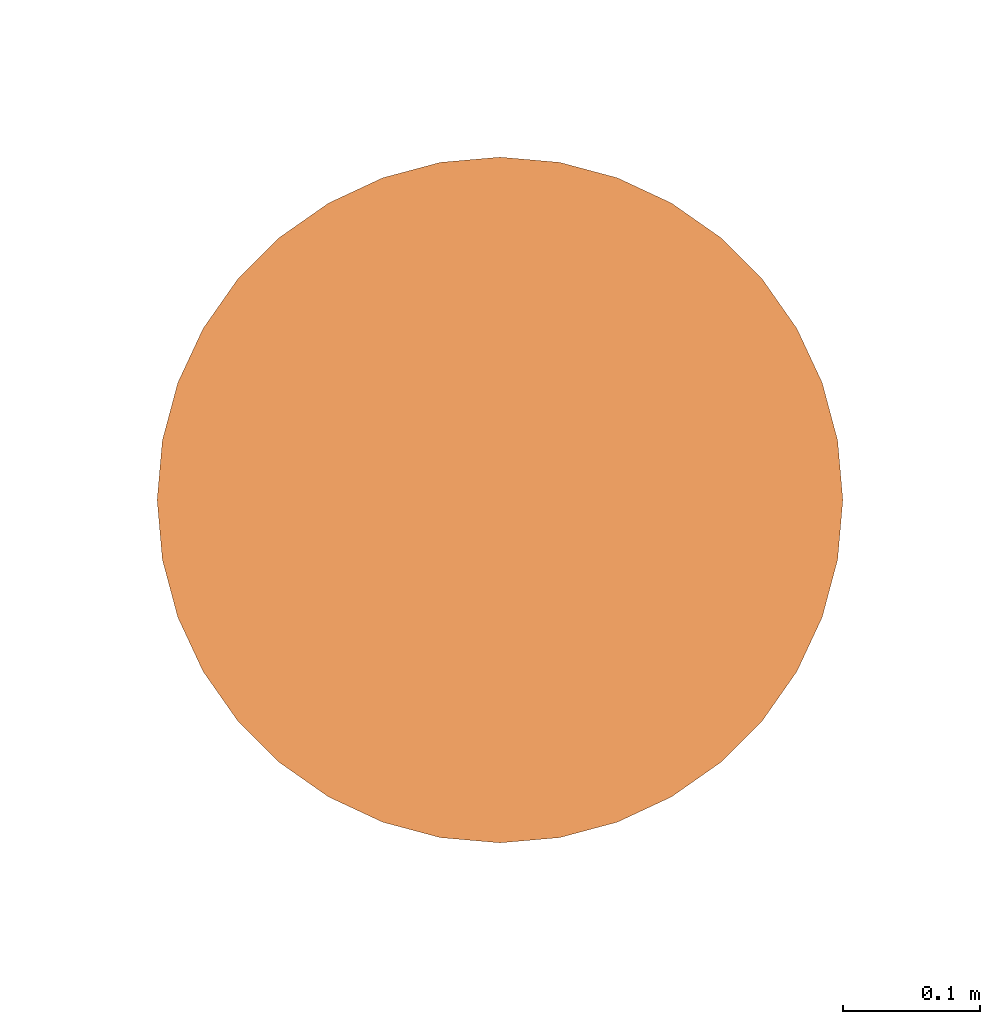
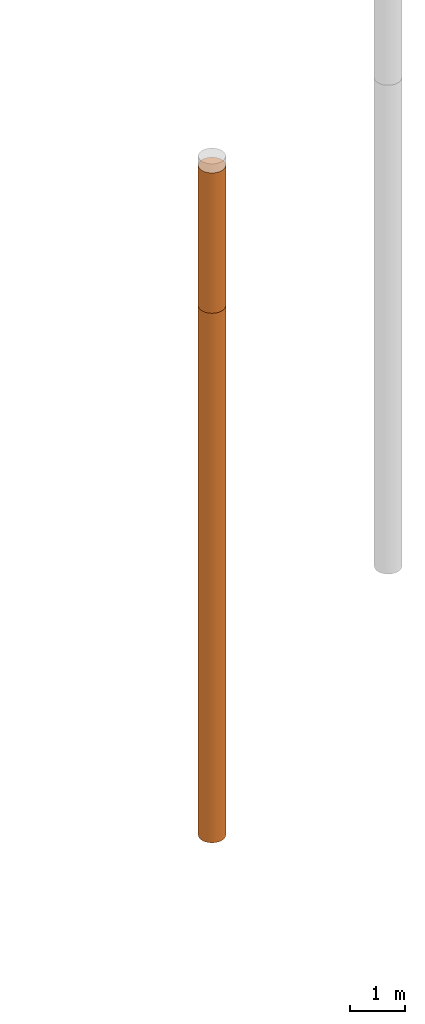
# One storey, part 4 of 8: 2 proxies.
"""IFC4 building model written with IfcOpenShell, lengths in metres."""

from ifc_helpers import new_model, entity, si_unit, converted_unit, frame, origin, place, context, subcontext, project, spatial, faceted_brep, material, element, save


model = new_model("IFC4")

# Units and contexts
model_context = context("Model", 3, precision=1e-05, world=origin())
body_context = subcontext(model_context, "Body", "Model", "MODEL_VIEW")
ifc_project = project(units=[si_unit("LENGTHUNIT", "METRE"), si_unit("AREAUNIT", "SQUARE_METRE"), si_unit("VOLUMEUNIT", "CUBIC_METRE"), converted_unit("PLANEANGLEUNIT", "DEGREE", entity("IfcPlaneAngleMeasure", 0.0174532925199433), si_unit("PLANEANGLEUNIT", "RADIAN"), dimensions=[0, 0, 0, 0, 0, 0, 0])], contexts=[model_context])

# Site, building, storey
site_placement = place(None, origin())
site = spatial("IfcSite", under=ifc_project, at=site_placement, CompositionType="ELEMENT")
building_placement = place(site_placement, origin())
building = spatial("IfcBuilding", under=site, at=building_placement, Name="Demo", CompositionType="ELEMENT")
storey_placement = place(building_placement, origin())
storey = spatial("IfcBuildingStorey", under=building, at=storey_placement, Name="Boden", CompositionType="ELEMENT", Elevation=0.0)

# Proxies
ifc_material_1 = material()
proxy_1_placement = place(storey_placement, frame((9.9, 9.49, -3.3)))
element("IfcBuildingElementProxy", 1, at=proxy_1_placement, inside=storey, material=ifc_material_1, Name="KB-05_Sand", PredefinedType="USERDEFINED", context=body_context, shape_type="Brep", body=[
    faceted_brep([(0.4962019382530525, 0.2934120444167329, 3.1), (0.5, 0.25, 3.1), (0.4962019382530525, 0.2065879555832671, 3.1), (0.4849231551964767, 0.1644949641685835, 3.1), (0.4665063509461107, 0.125, 3.1), (0.4415111107797439, 0.08930309757836585, 3.1), (0.4106969024216342, 0.05848888922025617, 3.1), (0.375, 0.0334936490538912, 3.1), (0.3355050358314166, 0.01507684480352327, 3.1), (0.2934120444167329, 0.003798061746947497, 3.1), (0.25, 0.0, 3.1), (0.2065879555832671, 0.003798061746947497, 3.1), (0.1644949641685835, 0.01507684480352327, 3.1), (0.125, 0.03349364905388939, 3.1), (0.08930309757836585, 0.05848888922025617, 3.1), (0.05848888922025617, 0.08930309757836585, 3.1), (0.0334936490538912, 0.125, 3.1), (0.01507684480352327, 0.1644949641685835, 3.1), (0.003798061746947497, 0.2065879555832671, 3.1), (0.0, 0.25, 3.1), (0.003798061746947497, 0.2934120444167329, 3.1), (0.01507684480352327, 0.3355050358314166, 3.1), (0.03349364905388939, 0.375, 3.1), (0.05848888922025435, 0.4106969024216342, 3.1), (0.08930309757836404, 0.4415111107797439, 3.1), (0.125, 0.4665063509461088, 3.1), (0.1644949641685816, 0.4849231551964767, 3.1), (0.2065879555832671, 0.4962019382530525, 3.1), (0.25, 0.5, 3.1), (0.2934120444167311, 0.4962019382530525, 3.1), (0.3355050358314166, 0.4849231551964767, 3.1), (0.375, 0.4665063509461107, 3.1), (0.4106969024216342, 0.4415111107797456, 3.1), (0.4415111107797439, 0.410696902421636, 3.1), (0.4665063509461088, 0.375, 3.1), (0.4849231551964767, 0.3355050358314184, 3.1), (0.5, 0.25, 0.0), (0.4962019382530525, 0.2934120444167329, 0.0), (0.4849231551964767, 0.3355050358314184, 0.0), (0.4665063509461088, 0.375, 0.0), (0.4415111107797439, 0.410696902421636, 0.0), (0.4106969024216342, 0.4415111107797456, 0.0), (0.375, 0.4665063509461107, 0.0), (0.3355050358314166, 0.4849231551964767, 0.0), (0.2934120444167311, 0.4962019382530525, 0.0), (0.25, 0.5, 0.0), (0.2065879555832671, 0.4962019382530507, 0.0), (0.1644949641685816, 0.4849231551964767, 0.0), (0.125, 0.4665063509461088, 0.0), (0.08930309757836404, 0.4415111107797439, 0.0), (0.05848888922025435, 0.4106969024216342, 0.0), (0.03349364905388939, 0.375, 0.0), (0.01507684480352327, 0.3355050358314166, 0.0), (0.003798061746947497, 0.2934120444167311, 0.0), (0.0, 0.25, 0.0), (0.003798061746947497, 0.2065879555832671, 0.0), (0.01507684480352327, 0.1644949641685816, 0.0), (0.0334936490538912, 0.125, 0.0), (0.05848888922025617, 0.08930309757836404, 0.0), (0.08930309757836585, 0.05848888922025435, 0.0), (0.125, 0.03349364905388939, 0.0), (0.1644949641685835, 0.01507684480352327, 0.0), (0.2065879555832671, 0.003798061746947497, 0.0), (0.25, 0.0, 0.0), (0.2934120444167329, 0.003798061746947497, 0.0), (0.3355050358314166, 0.01507684480352327, 0.0), (0.375, 0.03349364905388939, 0.0), (0.4106969024216342, 0.05848888922025435, 0.0), (0.4415111107797439, 0.08930309757836404, 0.0), (0.4665063509461107, 0.125, 0.0), (0.4849231551964767, 0.1644949641685816, 0.0), (0.4962019382530525, 0.2065879555832671, 0.0), (0.5, 0.25, 3.1), (0.4962019382530525, 0.2934120444167329, 3.1), (0.4962019382530525, 0.2934120444167329, 0.0), (0.5, 0.25, 0.0), (0.4962019382530525, 0.2065879555832671, 3.1), (0.5, 0.25, 3.1), (0.5, 0.25, 0.0), (0.4962019382530525, 0.2065879555832671, 0.0), (0.4849231551964767, 0.1644949641685835, 3.1), (0.4962019382530525, 0.2065879555832671, 3.1), (0.4962019382530525, 0.2065879555832671, 0.0), (0.4849231551964767, 0.1644949641685816, 0.0), (0.4665063509461107, 0.125, 3.1), (0.4849231551964767, 0.1644949641685835, 3.1), (0.4849231551964767, 0.1644949641685816, 0.0), (0.4665063509461107, 0.125, 0.0), (0.4415111107797439, 0.08930309757836585, 3.1), (0.4665063509461107, 0.125, 3.1), (0.4665063509461107, 0.125, 0.0), (0.4415111107797439, 0.08930309757836404, 0.0), (0.4106969024216342, 0.05848888922025617, 3.1), (0.4415111107797439, 0.08930309757836585, 3.1), (0.4415111107797439, 0.08930309757836404, 0.0), (0.4106969024216342, 0.05848888922025435, 0.0), (0.375, 0.0334936490538912, 3.1), (0.4106969024216342, 0.05848888922025617, 3.1), (0.4106969024216342, 0.05848888922025435, 0.0), (0.375, 0.03349364905388939, 0.0), (0.3355050358314166, 0.01507684480352327, 3.1), (0.375, 0.0334936490538912, 3.1), (0.375, 0.03349364905388939, 0.0), (0.3355050358314166, 0.01507684480352327, 0.0), (0.2934120444167329, 0.003798061746947497, 3.1), (0.3355050358314166, 0.01507684480352327, 3.1), (0.3355050358314166, 0.01507684480352327, 0.0), (0.2934120444167329, 0.003798061746947497, 0.0), (0.25, 0.0, 3.1), (0.2934120444167329, 0.003798061746947497, 3.1), (0.2934120444167329, 0.003798061746947497, 0.0), (0.25, 0.0, 0.0), (0.2065879555832671, 0.003798061746947497, 3.1), (0.25, 0.0, 3.1), (0.25, 0.0, 0.0), (0.2065879555832671, 0.003798061746947497, 0.0), (0.1644949641685835, 0.01507684480352327, 3.1), (0.2065879555832671, 0.003798061746947497, 3.1), (0.2065879555832671, 0.003798061746947497, 0.0), (0.1644949641685835, 0.01507684480352327, 0.0), (0.125, 0.03349364905388939, 3.1), (0.1644949641685835, 0.01507684480352327, 3.1), (0.1644949641685835, 0.01507684480352327, 0.0), (0.125, 0.03349364905388939, 0.0), (0.08930309757836585, 0.05848888922025617, 3.1), (0.125, 0.03349364905388939, 3.1), (0.125, 0.03349364905388939, 0.0), (0.08930309757836585, 0.05848888922025435, 0.0), (0.05848888922025617, 0.08930309757836585, 3.1), (0.08930309757836585, 0.05848888922025617, 3.1), (0.08930309757836585, 0.05848888922025435, 0.0), (0.05848888922025617, 0.08930309757836404, 0.0), (0.0334936490538912, 0.125, 3.1), (0.05848888922025617, 0.08930309757836585, 3.1), (0.05848888922025617, 0.08930309757836404, 0.0), (0.0334936490538912, 0.125, 0.0), (0.01507684480352327, 0.1644949641685835, 3.1), (0.0334936490538912, 0.125, 3.1), (0.0334936490538912, 0.125, 0.0), (0.01507684480352327, 0.1644949641685816, 0.0), (0.003798061746947497, 0.2065879555832671, 3.1), (0.01507684480352327, 0.1644949641685835, 3.1), (0.01507684480352327, 0.1644949641685816, 0.0), (0.003798061746947497, 0.2065879555832671, 0.0), (0.0, 0.25, 3.1), (0.003798061746947497, 0.2065879555832671, 3.1), (0.003798061746947497, 0.2065879555832671, 0.0), (0.0, 0.25, 0.0), (0.003798061746947497, 0.2934120444167329, 3.1), (0.0, 0.25, 3.1), (0.0, 0.25, 0.0), (0.003798061746947497, 0.2934120444167311, 0.0), (0.01507684480352327, 0.3355050358314166, 3.1), (0.003798061746947497, 0.2934120444167329, 3.1), (0.003798061746947497, 0.2934120444167311, 0.0), (0.01507684480352327, 0.3355050358314166, 0.0), (0.03349364905388939, 0.375, 3.1), (0.01507684480352327, 0.3355050358314166, 3.1), (0.01507684480352327, 0.3355050358314166, 0.0), (0.03349364905388939, 0.375, 0.0), (0.05848888922025435, 0.4106969024216342, 3.1), (0.03349364905388939, 0.375, 3.1), (0.03349364905388939, 0.375, 0.0), (0.05848888922025435, 0.4106969024216342, 0.0), (0.08930309757836404, 0.4415111107797439, 3.1), (0.05848888922025435, 0.4106969024216342, 3.1), (0.05848888922025435, 0.4106969024216342, 0.0), (0.08930309757836404, 0.4415111107797439, 0.0), (0.125, 0.4665063509461088, 3.1), (0.08930309757836404, 0.4415111107797439, 3.1), (0.08930309757836404, 0.4415111107797439, 0.0), (0.125, 0.4665063509461088, 0.0), (0.1644949641685816, 0.4849231551964767, 3.1), (0.125, 0.4665063509461088, 3.1), (0.125, 0.4665063509461088, 0.0), (0.1644949641685816, 0.4849231551964767, 0.0), (0.2065879555832671, 0.4962019382530525, 3.1), (0.1644949641685816, 0.4849231551964767, 3.1), (0.1644949641685816, 0.4849231551964767, 0.0), (0.2065879555832671, 0.4962019382530507, 0.0), (0.25, 0.5, 3.1), (0.2065879555832671, 0.4962019382530525, 3.1), (0.2065879555832671, 0.4962019382530507, 0.0), (0.25, 0.5, 0.0), (0.2934120444167311, 0.4962019382530525, 3.1), (0.25, 0.5, 3.1), (0.25, 0.5, 0.0), (0.2934120444167311, 0.4962019382530525, 0.0), (0.3355050358314166, 0.4849231551964767, 3.1), (0.2934120444167311, 0.4962019382530525, 3.1), (0.2934120444167311, 0.4962019382530525, 0.0), (0.3355050358314166, 0.4849231551964767, 0.0), (0.375, 0.4665063509461107, 3.1), (0.3355050358314166, 0.4849231551964767, 3.1), (0.3355050358314166, 0.4849231551964767, 0.0), (0.375, 0.4665063509461107, 0.0), (0.4106969024216342, 0.4415111107797456, 3.1), (0.375, 0.4665063509461107, 3.1), (0.375, 0.4665063509461107, 0.0), (0.4106969024216342, 0.4415111107797456, 0.0), (0.4415111107797439, 0.410696902421636, 3.1), (0.4106969024216342, 0.4415111107797456, 3.1), (0.4106969024216342, 0.4415111107797456, 0.0), (0.4415111107797439, 0.410696902421636, 0.0), (0.4665063509461088, 0.375, 3.1), (0.4415111107797439, 0.410696902421636, 3.1), (0.4415111107797439, 0.410696902421636, 0.0), (0.4665063509461088, 0.375, 0.0), (0.4849231551964767, 0.3355050358314184, 3.1), (0.4665063509461088, 0.375, 3.1), (0.4665063509461088, 0.375, 0.0), (0.4849231551964767, 0.3355050358314184, 0.0), (0.4962019382530525, 0.2934120444167329, 3.1), (0.4849231551964767, 0.3355050358314184, 3.1), (0.4849231551964767, 0.3355050358314184, 0.0), (0.4962019382530525, 0.2934120444167329, 0.0)], [[[0, 1, 2, 3, 4, 5, 6, 7, 8, 9, 10, 11, 12, 13, 14, 15, 16, 17, 18, 19, 20, 21, 22, 23, 24, 25, 26, 27, 28, 29, 30, 31, 32, 33, 34, 35]], [[36, 37, 38, 39, 40, 41, 42, 43, 44, 45, 46, 47, 48, 49, 50, 51, 52, 53, 54, 55, 56, 57, 58, 59, 60, 61, 62, 63, 64, 65, 66, 67, 68, 69, 70, 71]], [[72, 73, 74, 75]], [[76, 77, 78, 79]], [[80, 81, 82, 83]], [[84, 85, 86, 87]], [[88, 89, 90, 91]], [[92, 93, 94, 95]], [[96, 97, 98, 99]], [[100, 101, 102, 103]], [[104, 105, 106, 107]], [[108, 109, 110, 111]], [[112, 113, 114, 115]], [[116, 117, 118, 119]], [[120, 121, 122, 123]], [[124, 125, 126, 127]], [[128, 129, 130, 131]], [[132, 133, 134, 135]], [[136, 137, 138, 139]], [[140, 141, 142, 143]], [[144, 145, 146, 147]], [[148, 149, 150, 151]], [[152, 153, 154, 155]], [[156, 157, 158, 159]], [[160, 161, 162, 163]], [[164, 165, 166, 167]], [[168, 169, 170, 171]], [[172, 173, 174, 175]], [[176, 177, 178, 179]], [[180, 181, 182, 183]], [[184, 185, 186, 187]], [[188, 189, 190, 191]], [[192, 193, 194, 195]], [[196, 197, 198, 199]], [[200, 201, 202, 203]], [[204, 205, 206, 207]], [[208, 209, 210, 211]], [[212, 213, 214, 215]]], orient=[[False], [False], [False], [False], [False], [False], [False], [False], [False], [False], [False], [False], [False], [False], [False], [False], [False], [False], [False], [False], [False], [False], [False], [False], [False], [False], [False], [False], [False], [False], [False], [False], [False], [False], [False], [False], [False], [False]]),
])
ifc_material_2 = material()
proxy_2_placement = place(storey_placement, frame((9.9, 9.49, -15.0)))
element("IfcBuildingElementProxy", 2, at=proxy_2_placement, inside=storey, material=ifc_material_2, Name="KB-05_Kies", PredefinedType="USERDEFINED", context=body_context, shape_type="Brep", body=[
    faceted_brep([(0.4962019382530525, 0.2934120444167329, 11.7), (0.5, 0.25, 11.7), (0.4962019382530525, 0.2065879555832671, 11.7), (0.4849231551964767, 0.1644949641685835, 11.7), (0.4665063509461107, 0.125, 11.7), (0.4415111107797439, 0.08930309757836585, 11.7), (0.4106969024216342, 0.05848888922025617, 11.7), (0.375, 0.0334936490538912, 11.7), (0.3355050358314166, 0.01507684480352327, 11.7), (0.2934120444167329, 0.003798061746947497, 11.7), (0.25, 0.0, 11.7), (0.2065879555832671, 0.003798061746947497, 11.7), (0.1644949641685835, 0.01507684480352327, 11.7), (0.125, 0.03349364905388939, 11.7), (0.08930309757836585, 0.05848888922025617, 11.7), (0.05848888922025617, 0.08930309757836585, 11.7), (0.0334936490538912, 0.125, 11.7), (0.01507684480352327, 0.1644949641685835, 11.7), (0.003798061746947497, 0.2065879555832671, 11.7), (0.0, 0.25, 11.7), (0.003798061746947497, 0.2934120444167329, 11.7), (0.01507684480352327, 0.3355050358314166, 11.7), (0.03349364905388939, 0.375, 11.7), (0.05848888922025435, 0.4106969024216342, 11.7), (0.08930309757836404, 0.4415111107797439, 11.7), (0.125, 0.4665063509461088, 11.7), (0.1644949641685816, 0.4849231551964767, 11.7), (0.2065879555832671, 0.4962019382530525, 11.7), (0.25, 0.5, 11.7), (0.2934120444167311, 0.4962019382530525, 11.7), (0.3355050358314166, 0.4849231551964767, 11.7), (0.375, 0.4665063509461107, 11.7), (0.4106969024216342, 0.4415111107797456, 11.7), (0.4415111107797439, 0.410696902421636, 11.7), (0.4665063509461088, 0.375, 11.7), (0.4849231551964767, 0.3355050358314184, 11.7), (0.5, 0.2499999999999982, 0.0), (0.4962019382530525, 0.2934120444167329, 0.0), (0.4849231551964767, 0.3355050358314166, 0.0), (0.4665063509461088, 0.375, 0.0), (0.4415111107797439, 0.4106969024216342, 0.0), (0.4106969024216342, 0.4415111107797439, 0.0), (0.375, 0.4665063509461088, 0.0), (0.3355050358314166, 0.4849231551964767, 0.0), (0.2934120444167311, 0.4962019382530507, 0.0), (0.25, 0.4999999999999982, 0.0), (0.2065879555832671, 0.4962019382530507, 0.0), (0.1644949641685816, 0.4849231551964749, 0.0), (0.125, 0.4665063509461088, 0.0), (0.08930309757836404, 0.441511110779742, 0.0), (0.05848888922025435, 0.4106969024216323, 0.0), (0.03349364905388939, 0.3749999999999982, 0.0), (0.01507684480352327, 0.3355050358314147, 0.0), (0.003798061746947497, 0.2934120444167311, 0.0), (0.0, 0.2499999999999982, 0.0), (0.003798061746947497, 0.2065879555832653, 0.0), (0.01507684480352327, 0.1644949641685816, 0.0), (0.0334936490538912, 0.1249999999999982, 0.0), (0.05848888922025617, 0.08930309757836404, 0.0), (0.08930309757836585, 0.05848888922025435, 0.0), (0.125, 0.03349364905388939, 0.0), (0.1644949641685835, 0.01507684480352145, 0.0), (0.2065879555832671, 0.003798061746947497, 0.0), (0.25, -1.818989403545857e-15, 0.0), (0.2934120444167329, 0.003798061746947497, 0.0), (0.3355050358314166, 0.01507684480352145, 0.0), (0.375, 0.03349364905388939, 0.0), (0.4106969024216342, 0.05848888922025435, 0.0), (0.4415111107797439, 0.08930309757836404, 0.0), (0.4665063509461107, 0.1249999999999982, 0.0), (0.4849231551964767, 0.1644949641685816, 0.0), (0.4962019382530525, 0.2065879555832653, 0.0), (0.5, 0.25, 11.7), (0.4962019382530525, 0.2934120444167329, 11.7), (0.4962019382530525, 0.2934120444167329, 0.0), (0.5, 0.2499999999999982, 0.0), (0.4962019382530525, 0.2065879555832671, 11.7), (0.5, 0.25, 11.7), (0.5, 0.2499999999999982, 0.0), (0.4962019382530525, 0.2065879555832653, 0.0), (0.4849231551964767, 0.1644949641685835, 11.7), (0.4962019382530525, 0.2065879555832671, 11.7), (0.4962019382530525, 0.2065879555832653, 0.0), (0.4849231551964767, 0.1644949641685816, 0.0), (0.4665063509461107, 0.125, 11.7), (0.4849231551964767, 0.1644949641685835, 11.7), (0.4849231551964767, 0.1644949641685816, 0.0), (0.4665063509461107, 0.1249999999999982, 0.0), (0.4415111107797439, 0.08930309757836585, 11.7), (0.4665063509461107, 0.125, 11.7), (0.4665063509461107, 0.1249999999999982, 0.0), (0.4415111107797439, 0.08930309757836404, 0.0), (0.4106969024216342, 0.05848888922025617, 11.7), (0.4415111107797439, 0.08930309757836585, 11.7), (0.4415111107797439, 0.08930309757836404, 0.0), (0.4106969024216342, 0.05848888922025435, 0.0), (0.375, 0.0334936490538912, 11.7), (0.4106969024216342, 0.05848888922025617, 11.7), (0.4106969024216342, 0.05848888922025435, 0.0), (0.375, 0.03349364905388939, 0.0), (0.3355050358314166, 0.01507684480352327, 11.7), (0.375, 0.0334936490538912, 11.7), (0.375, 0.03349364905388939, 0.0), (0.3355050358314166, 0.01507684480352145, 0.0), (0.2934120444167329, 0.003798061746947497, 11.7), (0.3355050358314166, 0.01507684480352327, 11.7), (0.3355050358314166, 0.01507684480352145, 0.0), (0.2934120444167329, 0.003798061746947497, 0.0), (0.25, 0.0, 11.7), (0.2934120444167329, 0.003798061746947497, 11.7), (0.2934120444167329, 0.003798061746947497, 0.0), (0.25, -1.818989403545857e-15, 0.0), (0.2065879555832671, 0.003798061746947497, 11.7), (0.25, 0.0, 11.7), (0.25, -1.818989403545857e-15, 0.0), (0.2065879555832671, 0.003798061746947497, 0.0), (0.1644949641685835, 0.01507684480352327, 11.7), (0.2065879555832671, 0.003798061746947497, 11.7), (0.2065879555832671, 0.003798061746947497, 0.0), (0.1644949641685835, 0.01507684480352145, 0.0), (0.125, 0.03349364905388939, 11.7), (0.1644949641685835, 0.01507684480352327, 11.7), (0.1644949641685835, 0.01507684480352145, 0.0), (0.125, 0.03349364905388939, 0.0), (0.08930309757836585, 0.05848888922025617, 11.7), (0.125, 0.03349364905388939, 11.7), (0.125, 0.03349364905388939, 0.0), (0.08930309757836585, 0.05848888922025435, 0.0), (0.05848888922025617, 0.08930309757836585, 11.7), (0.08930309757836585, 0.05848888922025617, 11.7), (0.08930309757836585, 0.05848888922025435, 0.0), (0.05848888922025617, 0.08930309757836404, 0.0), (0.0334936490538912, 0.125, 11.7), (0.05848888922025617, 0.08930309757836585, 11.7), (0.05848888922025617, 0.08930309757836404, 0.0), (0.0334936490538912, 0.1249999999999982, 0.0), (0.01507684480352327, 0.1644949641685835, 11.7), (0.0334936490538912, 0.125, 11.7), (0.0334936490538912, 0.1249999999999982, 0.0), (0.01507684480352327, 0.1644949641685816, 0.0), (0.003798061746947497, 0.2065879555832671, 11.7), (0.01507684480352327, 0.1644949641685835, 11.7), (0.01507684480352327, 0.1644949641685816, 0.0), (0.003798061746947497, 0.2065879555832653, 0.0), (0.0, 0.25, 11.7), (0.003798061746947497, 0.2065879555832671, 11.7), (0.003798061746947497, 0.2065879555832653, 0.0), (0.0, 0.2499999999999982, 0.0), (0.003798061746947497, 0.2934120444167329, 11.7), (0.0, 0.25, 11.7), (0.0, 0.2499999999999982, 0.0), (0.003798061746947497, 0.2934120444167311, 0.0), (0.01507684480352327, 0.3355050358314166, 11.7), (0.003798061746947497, 0.2934120444167329, 11.7), (0.003798061746947497, 0.2934120444167311, 0.0), (0.01507684480352327, 0.3355050358314147, 0.0), (0.03349364905388939, 0.375, 11.7), (0.01507684480352327, 0.3355050358314166, 11.7), (0.01507684480352327, 0.3355050358314147, 0.0), (0.03349364905388939, 0.3749999999999982, 0.0), (0.05848888922025435, 0.4106969024216342, 11.7), (0.03349364905388939, 0.375, 11.7), (0.03349364905388939, 0.3749999999999982, 0.0), (0.05848888922025435, 0.4106969024216323, 0.0), (0.08930309757836404, 0.4415111107797439, 11.7), (0.05848888922025435, 0.4106969024216342, 11.7), (0.05848888922025435, 0.4106969024216323, 0.0), (0.08930309757836404, 0.441511110779742, 0.0), (0.125, 0.4665063509461088, 11.7), (0.08930309757836404, 0.4415111107797439, 11.7), (0.08930309757836404, 0.441511110779742, 0.0), (0.125, 0.4665063509461088, 0.0), (0.1644949641685816, 0.4849231551964767, 11.7), (0.125, 0.4665063509461088, 11.7), (0.125, 0.4665063509461088, 0.0), (0.1644949641685816, 0.4849231551964749, 0.0), (0.2065879555832671, 0.4962019382530525, 11.7), (0.1644949641685816, 0.4849231551964767, 11.7), (0.1644949641685816, 0.4849231551964749, 0.0), (0.2065879555832671, 0.4962019382530507, 0.0), (0.25, 0.5, 11.7), (0.2065879555832671, 0.4962019382530525, 11.7), (0.2065879555832671, 0.4962019382530507, 0.0), (0.25, 0.4999999999999982, 0.0), (0.2934120444167311, 0.4962019382530525, 11.7), (0.25, 0.5, 11.7), (0.25, 0.4999999999999982, 0.0), (0.2934120444167311, 0.4962019382530507, 0.0), (0.3355050358314166, 0.4849231551964767, 11.7), (0.2934120444167311, 0.4962019382530525, 11.7), (0.2934120444167311, 0.4962019382530507, 0.0), (0.3355050358314166, 0.4849231551964767, 0.0), (0.375, 0.4665063509461107, 11.7), (0.3355050358314166, 0.4849231551964767, 11.7), (0.3355050358314166, 0.4849231551964767, 0.0), (0.375, 0.4665063509461088, 0.0), (0.4106969024216342, 0.4415111107797456, 11.7), (0.375, 0.4665063509461107, 11.7), (0.375, 0.4665063509461088, 0.0), (0.4106969024216342, 0.4415111107797439, 0.0), (0.4415111107797439, 0.410696902421636, 11.7), (0.4106969024216342, 0.4415111107797456, 11.7), (0.4106969024216342, 0.4415111107797439, 0.0), (0.4415111107797439, 0.4106969024216342, 0.0), (0.4665063509461088, 0.375, 11.7), (0.4415111107797439, 0.410696902421636, 11.7), (0.4415111107797439, 0.4106969024216342, 0.0), (0.4665063509461088, 0.375, 0.0), (0.4849231551964767, 0.3355050358314184, 11.7), (0.4665063509461088, 0.375, 11.7), (0.4665063509461088, 0.375, 0.0), (0.4849231551964767, 0.3355050358314166, 0.0), (0.4962019382530525, 0.2934120444167329, 11.7), (0.4849231551964767, 0.3355050358314184, 11.7), (0.4849231551964767, 0.3355050358314166, 0.0), (0.4962019382530525, 0.2934120444167329, 0.0)], [[[0, 1, 2, 3, 4, 5, 6, 7, 8, 9, 10, 11, 12, 13, 14, 15, 16, 17, 18, 19, 20, 21, 22, 23, 24, 25, 26, 27, 28, 29, 30, 31, 32, 33, 34, 35]], [[36, 37, 38, 39, 40, 41, 42, 43, 44, 45, 46, 47, 48, 49, 50, 51, 52, 53, 54, 55, 56, 57, 58, 59, 60, 61, 62, 63, 64, 65, 66, 67, 68, 69, 70, 71]], [[72, 73, 74, 75]], [[76, 77, 78, 79]], [[80, 81, 82, 83]], [[84, 85, 86, 87]], [[88, 89, 90, 91]], [[92, 93, 94, 95]], [[96, 97, 98, 99]], [[100, 101, 102, 103]], [[104, 105, 106, 107]], [[108, 109, 110, 111]], [[112, 113, 114, 115]], [[116, 117, 118, 119]], [[120, 121, 122, 123]], [[124, 125, 126, 127]], [[128, 129, 130, 131]], [[132, 133, 134, 135]], [[136, 137, 138, 139]], [[140, 141, 142, 143]], [[144, 145, 146, 147]], [[148, 149, 150, 151]], [[152, 153, 154, 155]], [[156, 157, 158, 159]], [[160, 161, 162, 163]], [[164, 165, 166, 167]], [[168, 169, 170, 171]], [[172, 173, 174, 175]], [[176, 177, 178, 179]], [[180, 181, 182, 183]], [[184, 185, 186, 187]], [[188, 189, 190, 191]], [[192, 193, 194, 195]], [[196, 197, 198, 199]], [[200, 201, 202, 203]], [[204, 205, 206, 207]], [[208, 209, 210, 211]], [[212, 213, 214, 215]]], orient=[[False], [False], [False], [False], [False], [False], [False], [False], [False], [False], [False], [False], [False], [False], [False], [False], [False], [False], [False], [False], [False], [False], [False], [False], [False], [False], [False], [False], [False], [False], [False], [False], [False], [False], [False], [False], [False], [False]]),
])

save(model, "model.ifc")
